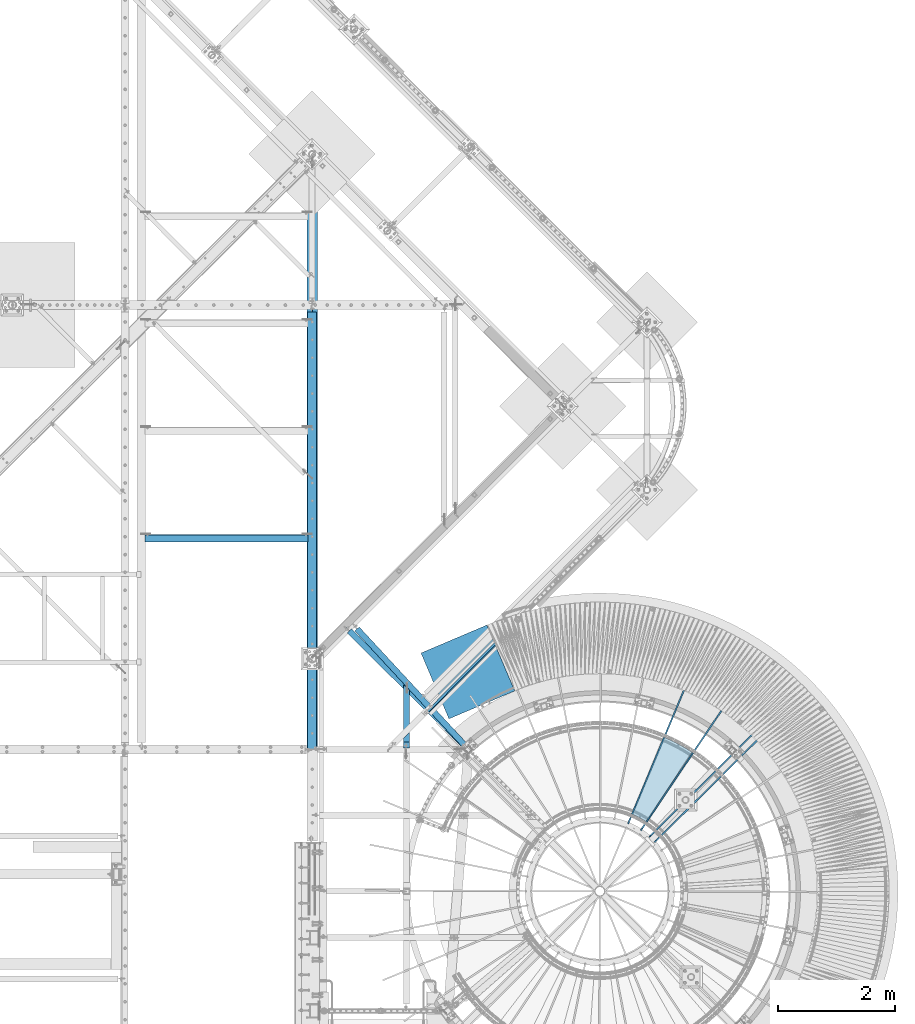
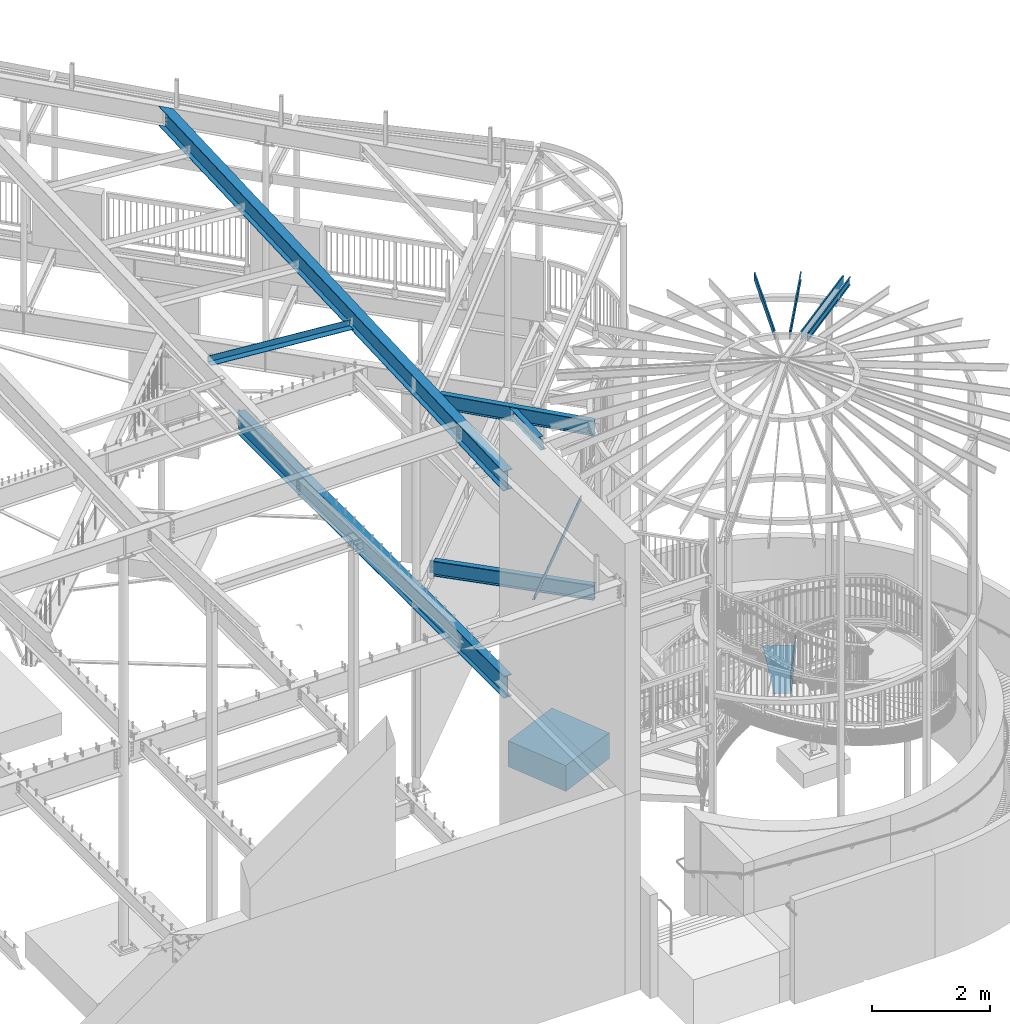
# One storey, part 367 of 975: 13 beams.
"""IFC2X3 building model written with IfcOpenShell, lengths in millimetres."""

from ifc_helpers import new_model, si_unit, frame, origin_with_axes, place, context, subcontext, project, spatial, faceted_brep, material, type_object, element, save


model = new_model("IFC2X3")

# Units and contexts
model_context = context("Model", 3, precision=1e-05, world=origin_with_axes())
body_context = subcontext(model_context, "Body", "Model", "MODEL_VIEW")
ifc_project = project(units=[si_unit("LENGTHUNIT", "METRE", prefix="MILLI"), si_unit("AREAUNIT", "SQUARE_METRE"), si_unit("VOLUMEUNIT", "CUBIC_METRE"), si_unit("MASSUNIT", "GRAM", prefix="KILO"), si_unit("TIMEUNIT", "SECOND"), si_unit("PLANEANGLEUNIT", "RADIAN"), si_unit("SOLIDANGLEUNIT", "STERADIAN"), si_unit("THERMODYNAMICTEMPERATUREUNIT", "DEGREE_CELSIUS"), si_unit("LUMINOUSINTENSITYUNIT", "LUMEN")], contexts=[model_context])

# Site, building, storey
site_placement = place(None, origin_with_axes())
site = spatial("IfcSite", under=ifc_project, at=site_placement, CompositionType="ELEMENT")
building_placement = place(site_placement, origin_with_axes())
building = spatial("IfcBuilding", under=site, at=building_placement, Name="Undefined", CompositionType="ELEMENT")
storey_placement = place(building_placement, origin_with_axes())
storey = spatial("IfcBuildingStorey", under=building, at=storey_placement, Name="Undefined", CompositionType="ELEMENT", Elevation=0.0)

# Beams
ifc_material_1 = material(Name="STEEL/Zero_Density")
beam_type_1 = type_object("IfcBeamType", PredefinedType="NOTDEFINED")
beam_1_placement = place(storey_placement, frame((32724.3729253223, 6579.01050316736, -266.7), z_axis=(-0.920504853712014, -0.390731127877757, 0.0), x_axis=(-0.390731127877756, 0.920504853712014, 0.0)))
element("IfcBeam", 1, at=beam_1_placement, inside=storey, type_object=beam_type_1, material=ifc_material_1, Name="SLAB", context=body_context, shape_type="Brep", body=[
    faceted_brep([(8.29459168016911e-10, 266.699999999988, -609.599999999988), (-1.25874066725373e-09, 266.699999999988, 609.599999999969), (1219.20000018737, 266.7, 609.599999999988), (1219.20000018801, 266.7, -609.599999999558), (-8.36735125631094e-10, -266.699999999988, 609.599999999988), (1219.20000018737, -266.7, 609.599999999988), (1.25146470963955e-09, -266.699999999988, -609.599999999969), (1219.20000018801, -266.7, -609.599999999558)], [[[0, 1, 2, 3]], [[1, 4, 5, 2]], [[4, 6, 7, 5]], [[6, 0, 3, 7]], [[5, 7, 3, 2]], [[6, 4, 1, 0]]]),
])
ifc_material_2 = material(Name="STEEL/A36")
beam_type_2 = type_object("IfcBeamType", PredefinedType="NOTDEFINED")
beam_2_placement = place(storey_placement, frame((35957.0868375578, 5220.79160408147, 1581.11695574218), z_axis=(0.55181688871509, 0.83396529983495, 1.46527781907935e-10), x_axis=(-0.589702519000131, 0.390193464000115, 0.707106781000218)))
element("IfcBeam", 2, at=beam_2_placement, inside=storey, type_object=beam_type_2, material=ifc_material_2, Name="TREAD", context=body_context, shape_type="Brep", body=[
    faceted_brep([(25.4000001621371, 1.5874997143419, 653.28751700326), (1.61144271260127e-08, 1.58750000026703, 653.458911680114), (-1.96268956642598e-08, -1.58749999973588, 653.437487347819), (15.8745748038546, -1.5875001784334, 653.330368544412), (-120.373022221533, -103.76749224318, 653.560250726816), (-154.208562872085, -137.603032237963, 653.560249286144), (-49.0005534961238, -242.811041643061, 652.140399877677), (-46.7554894721361, -240.565977619684, 652.140399877557), (-149.718432901582, -137.603030988068, 653.529952160912), (-118.287540217565, -106.172138299769, 653.529952144057), (82.2634121742994, -374.075007349978, 638.193006315465), (84.508476198167, -371.829943326711, 638.193006315345), (212.601306559884, -504.412901568812, 612.134347567509), (214.846370562875, -502.167837565145, 612.134347570151), (261.055176792581, -530.596712595621, 601.111823144849), (259.197053542079, -528.103470062568, 601.754434690294), (248.701623596196, -536.023091227627, 602.134831213494), (248.362633442506, -540.174228440612, 601.571851715846), (250.921725105154, -538.24319290819, 601.479100122608), (25.4000001865188, 1.58749971376164, -768.618736200977), (-118.287540216395, -106.172138302336, -768.542582766611), (-149.718433278054, -137.603031368186, -768.542582749815), (-92.8426928760819, -194.478774201189, -768.783692225286), (-95.087756899542, -196.723838224048, -768.783692225159), (-154.208562871598, -137.603032235413, -768.533065523057), (-120.373022220361, -103.767492245748, -768.533065418116), (15.8745748282345, -1.58750017901184, -768.605275732323), (-1.58015609486029e-08, -1.58750000031432, -768.571627720263), (1.99397618416697e-08, 1.58749999968677, -768.564897939472), (-21.2434099455131, -266.078057151808, -776.330856581004), (-23.4884739689005, -268.323121174595, -776.330856580884), (49.7927349215133, -337.114201961485, -791.08236047571), (47.5476709198538, -339.35926596382, -791.082360478347), (66.437802308692, -335.979336534963, -793.502619428495), (56.3071310127107, -343.628597994977, -793.115412720523), (53.7487404151489, -345.560335457225, -793.01762786691), (54.0919957188744, -341.413461775162, -792.424099714608), (64.5845451579717, -333.490960101732, -792.825137753654)], [[[0, 1, 2, 3, 4, 5, 6, 7, 8, 9]], [[7, 6, 10, 11]], [[11, 10, 12, 13]], [[14, 15, 16, 13, 12, 17, 18]], [[19, 20, 21, 22, 23, 24, 25, 26, 27, 28]], [[29, 30, 23, 22]], [[31, 32, 30, 29]], [[33, 34, 35, 32, 31, 36, 37]], [[34, 33, 14, 18]], [[35, 34, 18, 17]], [[10, 6, 5, 24, 23, 30, 32, 35, 17, 12]], [[25, 24, 5, 4]], [[26, 25, 4, 3]], [[27, 26, 3, 2]], [[28, 27, 2, 1]], [[19, 28, 1, 0]], [[20, 19, 0, 9]], [[20, 9, 8, 21]], [[36, 31, 29, 22, 21, 8, 7, 11, 13, 16]], [[37, 36, 16, 15]], [[33, 37, 15, 14]]]),
])
beam_type_3 = type_object("IfcBeamType", Name="L5X5X5/16", PredefinedType="NOTDEFINED")
beam_3_placement = place(storey_placement, frame((26920.8249998945, 9421.67185630478, 8298.06085423874), z_axis=(0.0796654699609281, 0.0, 0.996821655511107), x_axis=(0.996821655511107, 0.0, -0.0796654699609281)))
element("IfcBeam", 3, at=beam_3_placement, inside=storey, type_object=beam_type_3, material=ifc_material_2, ObjectType="L5X5X5/16", context=body_context, shape_type="Brep", body=[
    faceted_brep([(67.8053474811386, 63.5, -63.5000000000291), (67.805347481346, 63.5, 63.5000000000564), (2852.95282830662, 63.5, 63.5000000004839), (2852.9528283064, 63.5, -63.4999999996035), (67.805347481346, 55.5625, 63.5000000000564), (2852.95282830662, 55.5625, 63.5000000004839), (67.8053474811495, 55.5625, -55.5625000000236), (2852.95282830642, 55.5625, -55.562499999598), (67.8053474811495, -63.5, -55.5625000000236), (2852.95282830642, -63.5, -55.562499999598), (67.8053474811386, -63.5, -63.5000000000291), (2852.9528283064, -63.5, -63.4999999996035)], [[[0, 1, 2, 3]], [[1, 4, 5, 2]], [[4, 6, 7, 5]], [[6, 8, 9, 7]], [[8, 10, 11, 9]], [[10, 0, 3, 11]], [[5, 7, 9, 11, 3, 2]], [[10, 8, 6, 4, 1, 0]]]),
])
beam_type_4 = type_object("IfcBeamType", PredefinedType="NOTDEFINED")
beam_4_placement = place(storey_placement, frame((32374.8608284943, 7069.9146273848, 3938.58749694824), z_axis=(-0.706192932930278, -0.708019449930108, 0.0), x_axis=(0.708019449930107, -0.706192932930278, 0.0)))
element("IfcBeam", 4, at=beam_4_placement, inside=storey, type_object=beam_type_4, material=ifc_material_2, Name="DECK_EDGE", context=body_context, shape_type="Brep", body=[
    faceted_brep([(1.03318598121405e-09, -1.58750000000009, -1524.00000000109), (-1.04046193882823e-09, -1.58750000000009, 1524.0000000011), (-1.04046193882823e-09, 1.58750000000009, 1524.0000000011), (1.03318598121405e-09, 1.58750000000009, -1524.00000000109), (47.6250001214066, 1.58750000000009, 1524.00000000113), (47.6250001235167, 1.58750000000009, -1524.00000000107), (50.8000001235196, -1.58750000000009, -1524.00000000106), (50.8000001214168, -1.58750000000009, 1524.00000000113), (47.6250001214503, 96.837499999901, 1524.00000000113), (47.625000123473, 96.8374999999951, -1524.00000000106), (50.8000001234759, 104.502628762961, -1524.00000000106), (50.8000001214605, 104.502628762867, 1524.00000000113), (38.6447461584321, 87.8572448731024, 1524.00000000113), (38.6447461604548, 87.8572448731024, -1524.00000000107), (36.3996819826862, 90.102308757891, 1524.00000000112), (36.3996819847016, 90.102308757891, -1524.00000000107)], [[[0, 1, 2, 3]], [[3, 2, 4, 5]], [[1, 0, 6, 7]], [[5, 4, 8, 9]], [[7, 6, 10, 11]], [[9, 8, 12, 13]], [[8, 4, 2, 1, 7, 11, 14, 12]], [[11, 10, 15, 14]], [[10, 6, 0, 3, 5, 9, 13, 15]], [[14, 15, 13, 12]]]),
])
ifc_material_3 = material(Name="STEEL/A992")
beam_type_5 = type_object("IfcBeamType", Name="W8X10", PredefinedType="NOTDEFINED")
beam_5_placement = place(storey_placement, frame((31442.0252503397, 5823.93958142941, 7167.73433980447), z_axis=(-3.00000101560727e-09, -0.0416429379845367, 0.999132556629007), x_axis=(6.79999987285209e-08, 0.999132556629005, 0.0416429379845369)))
element("IfcBeam", 5, at=beam_5_placement, inside=storey, type_object=beam_type_5, material=ifc_material_3, Name="BEAM", ObjectType="W8X10", context=body_context, shape_type="Brep", body=[
    faceted_brep([(113.270167425701, -2.38125000002765, 72.9173595796419), (113.27016710125, 2.38124999997308, 72.9173595796583), (26.8264670258059, 2.3812500000713, 76.520254528531), (26.8264673502581, -2.38124999992942, 76.5202545285256), (118.1662885742, -2.38125000003129, 73.6808629287971), (118.166288249748, 2.38124999996944, 73.6808629288134), (122.397534609715, -2.38125000003129, 76.2599124924673), (122.397534285263, 2.38124999996944, 76.2599124924845), (125.319736679683, -2.38125000003129, 80.2618713537267), (125.319736355232, 2.38124999996944, 80.2618713537449), (126.488016008779, -2.38125000002037, 85.0774775537975), (126.488015684326, 2.38124999997672, 85.0774775538139), (127.110497485311, -50.8000000000029, 100.012500000008), (127.110490563808, 50.7999999999956, 100.012500000024), (126.91199388703, 50.7999999999884, 95.2500000000246), (126.91199718556, 2.38124999999127, 95.2500000000173), (126.911997510005, -2.38125000000946, 95.2500000000164), (126.912000808534, -50.8000000000102, 95.2500000000082), (19.6672390682243, -2.3812500001477, -95.2499999999827), (19.6672423668224, -50.8000000001484, -95.2499999999909), (984.987621692131, -50.8000000012071, -95.249999999769), (1037.33882905908, -2.38125000126456, -95.249999999749), (19.4687456900447, -50.8000000001521, -100.01249999999), (984.7891250145, -50.8000000012144, -100.012499999768), (19.468738768398, 50.7999999998465, -100.012499999973), (1094.64083883367, 50.7999999986641, -100.012499999727), (19.6672354451757, 50.7999999998538, -95.2499999999736), (19.667238743772, 2.38124999985303, -95.2499999999818), (1042.48812814435, 2.38124999872889, -95.2499999997463), (1094.8393355113, 50.7999999986678, -95.2499999997272), (1050.42799524959, 2.38124999897627, 95.2500000002292), (1102.77920261653, 50.7999999989152, 95.2500000002492), (1102.97769929416, 50.7999999989188, 100.012500000249), (993.125985474998, -50.8000000009561, 100.012500000207), (992.927488797366, -50.8000000009633, 95.2500000002092), (1045.27869616431, -2.38125000102445, 95.2500000002274)], [[[0, 1, 2, 3]], [[4, 5, 1, 0]], [[6, 7, 5, 4]], [[8, 9, 7, 6]], [[10, 11, 9, 8]], [[12, 13, 14, 15, 11, 10, 16, 17]], [[18, 19, 20, 21]], [[19, 22, 23, 20]], [[22, 24, 25, 23]], [[26, 27, 28, 29]], [[24, 26, 29, 25]], [[28, 30, 31, 32, 33, 34, 35, 21, 20, 23, 25, 29]], [[34, 33, 12, 17]], [[35, 34, 17, 16]], [[8, 6, 4, 0, 3, 18, 21, 35, 16, 10]], [[27, 26, 24, 22, 19, 18, 3, 2]], [[30, 28, 27, 2, 1, 5, 7, 9, 11, 15]], [[31, 30, 15, 14]], [[32, 31, 14, 13]], [[33, 32, 13, 12]]]),
])
beam_type_6 = type_object("IfcBeamType", Name="W12X14", PredefinedType="NOTDEFINED")
beam_6_placement = place(storey_placement, frame((30518.0365453104, 7958.56075366974, 7164.3875), z_axis=(0.0, 0.0, -1.0), x_axis=(0.679313234053469, -0.733848438057762, 0.0)))
element("IfcBeam", 6, at=beam_6_placement, inside=storey, type_object=beam_type_6, material=ifc_material_3, Name="BEAM", ObjectType="W12X14", context=body_context, shape_type="Brep", body=[
    faceted_brep([(33.898284058725, -2.38124999999127, -125.41249999811), (33.8982840587323, 2.38125000000218, -125.41249999811), (103.748284246476, 2.38125000000946, -125.41249999811), (103.748284246469, -2.38124999998763, -125.41249999811), (108.60836376453, 2.38125000000946, -126.379229920698), (108.608363764517, -2.38124999998763, -126.379229920698), (112.728540232683, 2.38125000000946, -129.132243821176), (112.728540232672, -2.38124999998399, -129.132243821176), (115.481554133165, 2.38125000000582, -133.25242028933), (115.481554133152, -2.38124999998399, -133.25242028933), (116.448284055739, -2.38124999998399, -138.112499807376), (116.448284055754, 2.38125000000946, -138.112499807376), (116.44828405589, 2.38125000000946, -144.4625), (116.448284055887, 50.799999999952, -144.4625), (116.448284055887, 50.799999999952, -150.8125), (116.448284055898, -50.7999999999302, -150.8125), (116.448284055898, -50.7999999999302, -144.4625), (116.448284055894, -2.38124999998763, -144.4625), (2850.97526016968, -50.7999999996973, 144.4625), (2850.97526016968, -50.7999999996973, 150.8125), (116.448284055898, -50.7999999999302, 150.8125), (116.448284055898, -50.7999999999302, 144.4625), (2850.9752601698, 50.8000000001848, 150.8125), (116.448284055887, 50.799999999952, 150.8125), (2850.9752601698, 50.8000000001848, 144.4625), (116.448284055887, 50.799999999952, 144.4625), (2850.97526016974, 2.38125000023865, 144.4625), (116.44828405589, 2.38125000000946, 144.4625), (103.748284246469, -2.38124999998763, 87.312500001889), (103.748284246476, 2.38125000000946, 87.312500001889), (33.8982840587323, 2.38125000000218, 87.312500001889), (33.898284058725, -2.38124999999127, 87.312500001889), (108.608363764517, -2.38124999998763, 88.2792299244766), (108.60836376453, 2.38125000000946, 88.2792299244766), (112.728540232672, -2.38124999998399, 91.032243824955), (112.728540232683, 2.38125000000946, 91.032243824955), (115.481554133152, -2.38124999998399, 95.1524202931087), (115.481554133165, 2.38125000000582, 95.1524202931087), (116.448284055739, -2.38124999998399, 100.012499811154), (116.448284055754, 2.38125000000946, 100.012499811154), (116.448284055894, -2.38124999998763, 144.4625), (2850.97526016973, -2.3812499997548, 144.4625), (2850.97526016974, 2.38125000023865, -144.4625), (2850.97526016973, -2.3812499997548, -144.4625), (2850.97526016968, -50.7999999996973, -144.4625), (2850.97526016968, -50.7999999996973, -150.8125), (2850.9752601698, 50.8000000001848, -150.8125), (2850.9752601698, 50.8000000001848, -144.4625)], [[[0, 1, 2, 3]], [[3, 2, 4, 5]], [[5, 4, 6, 7]], [[7, 6, 8, 9]], [[10, 11, 12, 13, 14, 15, 16, 17]], [[9, 8, 11, 10]], [[18, 19, 20, 21]], [[19, 22, 23, 20]], [[22, 24, 25, 23]], [[24, 26, 27, 25]], [[28, 29, 30, 31]], [[32, 33, 29, 28]], [[34, 35, 33, 32]], [[36, 37, 35, 34]], [[38, 39, 37, 36]], [[20, 23, 25, 27, 39, 38, 40, 21]], [[41, 18, 21, 40]], [[42, 26, 24, 22, 19, 18, 41, 43, 44, 45, 46, 47]], [[44, 43, 17, 16]], [[45, 44, 16, 15]], [[46, 45, 15, 14]], [[47, 46, 14, 13]], [[42, 47, 13, 12]], [[6, 4, 2, 1, 30, 29, 33, 35, 37, 39, 27, 26, 42, 12, 11, 8]], [[31, 30, 1, 0]], [[43, 41, 40, 38, 36, 34, 32, 28, 31, 0, 3, 5, 7, 9, 10, 17]]]),
])
beam_type_7 = type_object("IfcBeamType", PredefinedType="NOTDEFINED")
for number, where, z_axis, x_axis, name in (
    (7, (35441.2025205512, 4453.53242067196, 8885.0313138005), (0.135487061204178, 0.201171189303167, 0.970140922155439), (0.541933260795872, 0.804662506696911, -0.242541936908643), "STUD"),
    (8, (35222.7917757364, 4571.22908591713, 8885.0313138005), (0.0936371633068046, 0.223737955733079, 0.970140922140818), (0.374538296949224, 0.894927076878677, -0.242541936967119), "STUD"),
    (9, (35677.5218432192, 4250.35488212429, 8885.0313138005), (0.17213026717781, 0.170873527176511, 0.970140922150774), (0.688502032793625, 0.683475207795133, -0.242541936927299), "STUD"),
    (10, (37515.2026219233, 6253.4750946901, 8206.16015010101), (0.17213026717781, 0.170873527176511, 0.970140922150774), (-0.688502112820794, -0.683475127155158, 0.242541936995532), "STUD"),
):
    element("IfcBeam", number, at=place(storey_placement, frame(where, z_axis=z_axis, x_axis=x_axis)), inside=storey, type_object=beam_type_7, material=ifc_material_1, Name=name, context=body_context, shape_type="Brep", body=[
        faceted_brep([(-1.67347025126219e-10, 12.6999999998588, -76.2000000000985), (1.96450855582952e-10, 12.7000000001644, 76.2000000001021), (2798.98467503002, 12.7000000041553, 76.2000000028588), (2798.98467502966, 12.7000000038533, -76.1999999973427), (1.74622982740402e-10, -12.6999999998661, 76.2000000000985), (2798.98467503, -12.6999999958753, 76.2000000028534), (1.67347025126219e-10, -12.6999999998698, 73.0250000000947), (2798.98467502999, -12.6999999958789, 73.0250000028504), (1.89174897968769e-10, 9.52500000015425, 73.0250000000974), (2798.98467503001, 9.52500000414511, 73.0250000028532), (-1.60071067512035e-10, 9.52499999986321, -73.0250000000938), (2798.98467502966, 9.52500000385407, -73.0249999973398), (-1.81898940354586e-10, -12.7000000001608, -73.0250000000965), (2798.98467502964, -12.6999999961699, -73.0249999973416), (-1.92812876775861e-10, -12.7000000001717, -76.2000000001003), (2798.98467502963, -12.6999999961772, -76.1999999973455)], [[[0, 1, 2, 3]], [[1, 4, 5, 2]], [[4, 6, 7, 5]], [[6, 8, 9, 7]], [[8, 10, 11, 9]], [[10, 12, 13, 11]], [[12, 14, 15, 13]], [[14, 0, 3, 15]], [[5, 7, 9, 11, 13, 15, 3, 2]], [[14, 12, 10, 8, 6, 4, 1, 0]]]),
    ])
beam_type_8 = type_object("IfcBeamType", Name="W16X36", PredefinedType="NOTDEFINED")
beam_7_placement = place(storey_placement, frame((29832.3, 4250.17726068728, 7963.58607097624), z_axis=(0.0, -0.0415532340156015, 0.999136291375128), x_axis=(0.0, 0.999136291375128, 0.0415532340156014)))
element("IfcBeam", 11, at=beam_7_placement, inside=storey, type_object=beam_type_8, material=ifc_material_3, Name="BEAM", ObjectType="W16X36", context=body_context, shape_type="Brep", body=[
    faceted_brep([(9.11315692733751, -88.9000000000015, -190.500000000009), (8.65099744320742, -88.9000000000015, -201.612500000009), (11485.7005637631, -88.9000000000015, -201.612499998478), (11486.1627232584, -88.9000000000015, -190.499999998478), (9.11315692733751, -3.96875, -190.500000000009), (11571.1978475393, -3.96875, -190.499999998467), (24.9586249546837, -3.96875, 190.500000000015), (11587.0433159483, -3.96875, 190.500000001557), (24.9586249546837, -88.9000000000015, 190.500000000015), (11502.0081916674, -88.9000000000015, 190.500000001546), (25.4207844388138, -88.9000000000015, 201.612500000016), (11502.4703511627, -88.9000000000015, 201.612500001547), (25.4207844388138, 88.9000000000015, 201.612500000016), (11680.4878076012, 88.9000000000015, 201.612500001572), (24.9586249546837, 88.9000000000015, 190.500000000015), (11680.025648106, 88.9000000000015, 190.500000001569), (24.9586249546837, 3.96875, 190.500000000015), (11594.990523825, 3.96875, 190.500000001559), (9.11315692733751, 3.96875, -190.500000000009), (11579.145055416, 3.96875, -190.499999998467), (9.11315692733751, 88.9000000000015, -190.500000000009), (11664.180179697, 88.9000000000015, -190.499999998454), (8.65099744320742, 88.9000000000015, -201.612500000009), (11663.7180202017, 88.9000000000015, -201.612499998455)], [[[0, 1, 2, 3]], [[4, 0, 3, 5]], [[6, 4, 5, 7]], [[8, 6, 7, 9]], [[10, 8, 9, 11]], [[12, 10, 11, 13]], [[14, 12, 13, 15]], [[16, 14, 15, 17]], [[18, 16, 17, 19]], [[20, 18, 19, 21]], [[1, 0, 4, 6, 8, 10, 12, 14, 16, 18, 20, 22]], [[1, 22, 23, 2]], [[19, 17, 15, 13, 11, 9, 7, 5, 3, 2, 23, 21]], [[22, 20, 21, 23]]]),
])
beam_type_9 = type_object("IfcBeamType", Name="W18X35", PredefinedType="NOTDEFINED")
beam_8_placement = place(storey_placement, frame((29832.3, 4241.799609375, 3711.575), z_axis=(0.0, 0.0, 1.0), x_axis=(0.0, 1.0, 0.0)))
element("IfcBeam", 12, at=beam_8_placement, inside=storey, type_object=beam_type_9, material=ifc_material_3, Name="BEAM", ObjectType="W18X35", context=body_context, shape_type="Brep", body=[
    faceted_brep([(9120.98164062499, -3.96875, 200.025000000001), (9120.98164062499, 3.96875, 200.025000000001), (9044.78164043426, 3.96875, 200.025000000001), (9044.78164043426, -3.96875, 200.025000000001), (9039.92156091621, 3.96875, 200.991729922589), (9039.92156091621, -3.96875, 200.991729922589), (9035.80138444806, 3.96875, 203.744743823067), (9035.80138444806, -3.96875, 203.744743823067), (9033.04837054758, 3.96875, 207.86492029122), (9033.04837054758, -3.96875, 207.86492029122), (9032.08164062499, 3.96875, 212.724999809266), (9032.08164062499, -3.96875, 212.724999809266), (25.3999999999992, -76.1999999999998, 214.312499999999), (25.3999999999992, -3.96875, 214.312499999999), (9032.08164062499, -3.96875, 214.3125), (9032.08164062499, -76.2000000000007, 214.3125), (25.3999999999992, -76.1999999999998, 225.425), (9032.08164062499, -76.2000000000007, 225.425), (25.3999999999992, 76.1999999999998, 225.425), (9032.08164062499, 76.2000000000007, 225.425), (9025.73164062499, 76.2000000000007, 214.3125), (25.3999999999992, 76.1999999999998, 214.312499999999), (9032.08164062499, 76.2000000000007, 214.3125), (9032.08164062499, 3.96875, 214.3125), (25.3999999999992, 3.96875, 214.312499999999), (25.3999999999992, -76.1999999999998, -225.425), (25.3999999999992, -76.1999999999998, -214.3125), (25.3999999999992, -3.96875, -214.3125), (25.3999999999992, 3.96875, -214.3125), (25.3999999999992, 76.1999999999998, -214.3125), (25.3999999999992, 76.1999999999998, -225.425), (9032.08164062499, 3.96875, -214.3125), (9032.08164062499, 76.2000000000007, -214.3125), (9032.08164062499, 76.2000000000007, -225.425), (9032.08164062499, -76.2000000000007, -225.425), (9032.08164062499, -76.2000000000007, -214.3125), (9032.08164062499, -3.96875, -214.3125), (9032.08164062499, -3.96875, -212.724999809265), (9033.04837054758, -3.96875, -207.864920291219), (9035.80138444806, -3.96875, -203.744743823066), (9039.92156091621, -3.96875, -200.991729922588), (9044.78164043426, -3.96875, -200.025), (9120.98164062499, -3.96875, -200.025), (9120.98164062499, 3.96875, -200.025), (9039.92156091621, 3.96875, -200.991729922588), (9035.80138444806, 3.96875, -203.744743823066), (9033.04837054758, 3.96875, -207.864920291219), (9032.08164062499, 3.96875, -212.724999809265), (9044.78164043426, 3.96875, -200.025)], [[[0, 1, 2, 3]], [[3, 2, 4, 5]], [[5, 4, 6, 7]], [[7, 6, 8, 9]], [[9, 8, 10, 11]], [[12, 13, 14, 15]], [[16, 12, 15, 17]], [[18, 16, 17, 19]], [[20, 21, 18, 19, 22]], [[17, 15, 14, 11, 10, 23, 22, 19]], [[24, 21, 20, 22, 23]], [[25, 26, 27, 13, 12, 16, 18, 21, 24, 28, 29, 30]], [[29, 28, 31, 32]], [[30, 29, 32, 33]], [[25, 30, 33, 34]], [[26, 25, 34, 35]], [[27, 26, 35, 36]], [[0, 3, 5, 7, 9, 11, 14, 13, 27, 36, 37, 38, 39, 40, 41, 42]], [[1, 0, 42, 43]], [[44, 45, 46, 47, 31, 28, 24, 23, 10, 8, 6, 4, 2, 1, 43, 48]], [[42, 41, 48, 43]], [[40, 44, 48, 41]], [[39, 45, 44, 40]], [[38, 46, 45, 39]], [[37, 47, 46, 38]], [[36, 35, 34, 33, 32, 31, 47, 37]]]),
])
beam_type_10 = type_object("IfcBeamType", Name="W12X22", PredefinedType="NOTDEFINED")
beam_9_placement = place(storey_placement, frame((30381.9911632026, 7924.36122912999, 3781.425), z_axis=(0.0, 0.0, 1.0), x_axis=(0.709002820319978, -0.705205644318249, 0.0)))
element("IfcBeam", 13, at=beam_9_placement, inside=storey, type_object=beam_type_10, material=ifc_material_3, Name="BEAM", ObjectType="W12X22", context=body_context, shape_type="Brep", body=[
    faceted_brep([(28.629345388048, -3.174999999992, -130.174999999999), (28.6293967283709, 3.17500000000291, -130.174999999999), (104.829781962811, 3.17500000002474, -130.174999999999), (104.829781962826, -3.17499999997017, -130.174999999999), (109.689861480858, 3.17500000002474, -131.141729922587), (109.689861480869, -3.17499999997017, -131.141729922587), (113.810037949013, 3.17500000002838, -133.894743823065), (113.810037949022, -3.17499999997017, -133.894743823065), (116.563051849493, 3.17500000002838, -138.014920291219), (116.563051849502, -3.17499999997017, -138.014920291219), (117.529781772086, -3.17499999997017, -142.874999809264), (117.52978177208, 3.17500000002838, -142.874999809264), (117.529781772002, 3.17500000002838, -144.4625), (117.529781771989, 50.7999999999993, -144.4625), (117.529781771989, 50.7999999999993, -155.575), (117.529781772018, -50.7999999999411, -155.575), (117.529781772018, -50.7999999999411, -144.4625), (117.529781772004, -3.17499999997017, -144.4625), (2918.68379715625, -50.7999999992135, 144.4625), (2918.68379715625, -50.7999999992135, 155.575), (117.529781771851, -50.7999999999374, 155.575), (117.529781771851, -50.7999999999374, 144.4625), (2918.68379715619, 50.8000000007269, 155.575), (117.529781771826, 50.7999999999993, 155.575), (2918.68379715619, 50.8000000007269, 144.4625), (117.529781771826, 50.7999999999993, 144.4625), (2918.68379715622, 3.17500000075597, 144.4625), (117.529781771836, 3.17500000002838, 144.4625), (104.829781962655, -3.17499999997017, 130.175000000001), (104.829781962646, 3.17500000002474, 130.175000000001), (28.6293967283709, 3.17500000000291, 130.175000000001), (28.629345388048, -3.174999999992, 130.175000000001), (109.689861480701, -3.17499999997017, 131.141729922589), (109.689861480692, 3.17500000002474, 131.141729922589), (113.810037948855, -3.17499999997017, 133.894743823067), (113.810037948848, 3.17500000002838, 133.894743823067), (116.563051849336, -3.17499999997017, 138.01492029122), (116.563051849325, 3.17500000002838, 138.01492029122), (117.529781771924, -3.17499999997017, 142.874999809266), (117.529781771909, 3.17500000002838, 142.874999809266), (117.529781771838, -3.17499999996653, 144.4625), (2918.68379715623, -3.17499999923893, 144.4625), (2918.68379715622, 3.17500000075597, -144.4625), (2918.68379715623, -3.17499999923893, -144.4625), (2918.68379715625, -50.7999999992135, -144.4625), (2918.68379715625, -50.7999999992135, -155.575), (2918.68379715619, 50.8000000007269, -155.575), (2918.68379715619, 50.8000000007269, -144.4625)], [[[0, 1, 2, 3]], [[3, 2, 4, 5]], [[5, 4, 6, 7]], [[7, 6, 8, 9]], [[10, 11, 12, 13, 14, 15, 16, 17]], [[9, 8, 11, 10]], [[18, 19, 20, 21]], [[19, 22, 23, 20]], [[22, 24, 25, 23]], [[24, 26, 27, 25]], [[28, 29, 30, 31]], [[32, 33, 29, 28]], [[34, 35, 33, 32]], [[36, 37, 35, 34]], [[38, 39, 37, 36]], [[20, 23, 25, 27, 39, 38, 40, 21]], [[41, 18, 21, 40]], [[42, 26, 24, 22, 19, 18, 41, 43, 44, 45, 46, 47]], [[44, 43, 17, 16]], [[45, 44, 16, 15]], [[46, 45, 15, 14]], [[47, 46, 14, 13]], [[42, 47, 13, 12]], [[6, 4, 2, 1, 30, 29, 33, 35, 37, 39, 27, 26, 42, 12, 11, 8]], [[31, 30, 1, 0]], [[43, 41, 40, 38, 36, 34, 32, 28, 31, 0, 3, 5, 7, 9, 10, 17]]]),
])

save(model, "model.ifc")
